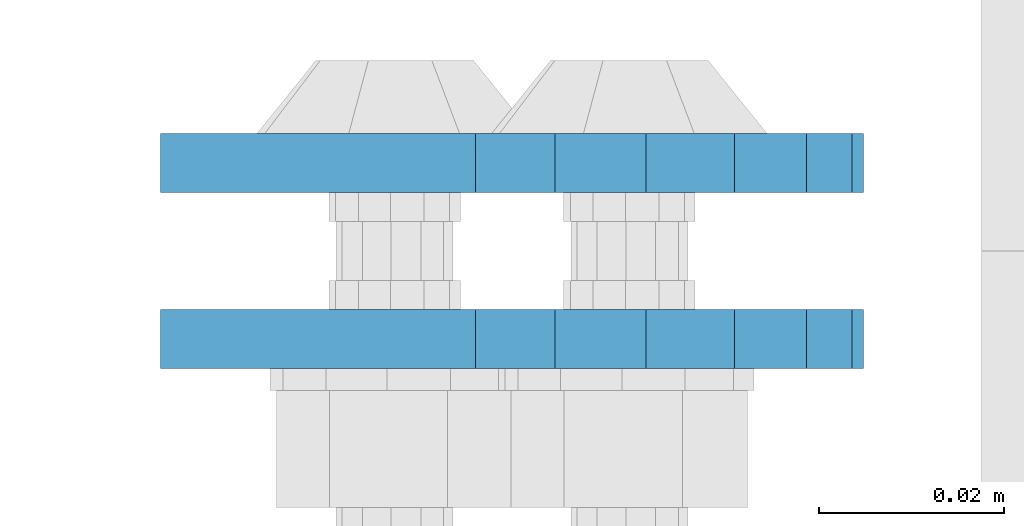
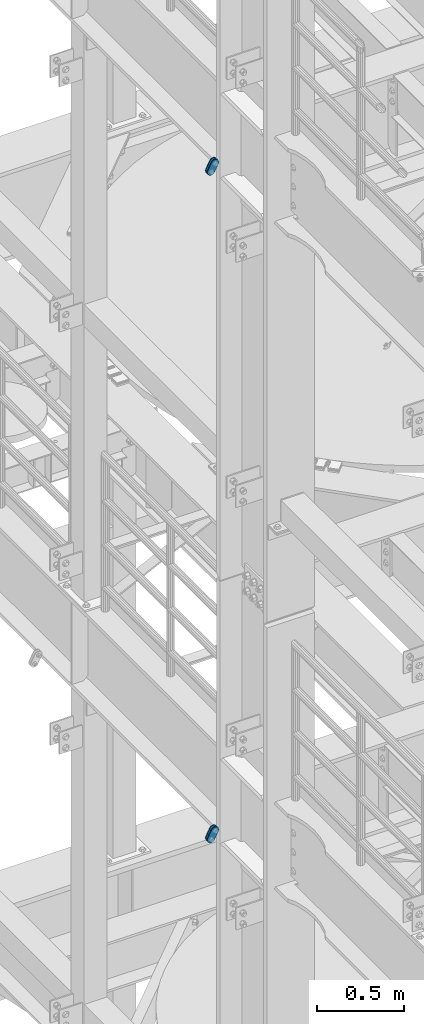
# One storey, part 1687 of 1876: 4 plates, 4 elements without a shape of their own.
"""IFC2X3 building model written with IfcOpenShell, lengths in millimetres."""

from ifc_helpers import new_model, si_unit, frame, origin_with_axes, place, context, subcontext, project, spatial, faceted_brep, material, type_object, element, aggregate, save


model = new_model("IFC2X3")

# Units and contexts
model_context = context("Model", 3, precision=1e-05, world=origin_with_axes())
body_context = subcontext(model_context, "Body", "Model", "MODEL_VIEW")
ifc_project = project(units=[si_unit("LENGTHUNIT", "METRE", prefix="MILLI"), si_unit("AREAUNIT", "SQUARE_METRE"), si_unit("VOLUMEUNIT", "CUBIC_METRE"), si_unit("MASSUNIT", "GRAM", prefix="KILO"), si_unit("TIMEUNIT", "SECOND"), si_unit("PLANEANGLEUNIT", "RADIAN"), si_unit("SOLIDANGLEUNIT", "STERADIAN"), si_unit("THERMODYNAMICTEMPERATUREUNIT", "DEGREE_CELSIUS"), si_unit("LUMINOUSINTENSITYUNIT", "LUMEN")], contexts=[model_context])

# Site, building, storey
site_placement = place(None, origin_with_axes())
site = spatial("IfcSite", under=ifc_project, at=site_placement, CompositionType="ELEMENT")
building_placement = place(site_placement, origin_with_axes())
building = spatial("IfcBuilding", under=site, at=building_placement, Name="Undefined", CompositionType="ELEMENT")
storey_placement = place(building_placement, origin_with_axes())
storey = spatial("IfcBuildingStorey", under=building, at=storey_placement, Name="Undefined", CompositionType="ELEMENT", Elevation=0.0)

# Assembly, plate
assembly_1_placement = place(storey_placement, origin_with_axes())
assembly_1 = element("IfcElementAssembly", 1, at=assembly_1_placement, inside=storey, Name="PLATE", AssemblyPlace="NOTDEFINED", PredefinedType="RIGID_FRAME")
ifc_material = material(Name="STEEL/A36")
plate_type = type_object("IfcPlateType", PredefinedType="NOTDEFINED")
plate_1_placement = place(assembly_1_placement, frame((-354.259224851121, 7610.47500303177, 17725.1776774809), z_axis=(0.894427191199916, 0.0, -0.447213595099958), x_axis=(-0.447213595099961, 6.99999707257306e-09, -0.894427191199915)))
plate_1 = element("IfcPlate", 2, at=plate_1_placement, type_object=plate_type, material=ifc_material, Name="PLATE", context=body_context, shape_type="Brep", body=[
    faceted_brep([(-8.59611645864788e-07, -3.17499999999654, 25.3999987589127), (1.93345873884391, -3.17499999999382, 35.1201580589886), (1.93345873884391, 3.17500000000564, 35.1201580589886), (-8.59611645864788e-07, 3.17500000000382, 25.3999987589132), (7.43948648259902, -3.17499999999109, 43.3605112870105), (7.43948648259902, 3.17500000000928, 43.3605112870105), (15.6798395242777, -3.17499999998654, 48.8665393096448), (15.6798395242777, 3.17500000001382, 48.8665393096448), (25.3999987589095, -3.17499999998199, 50.7999992370592), (25.3999987589095, 3.17500000001837, 50.7999992370592), (82.196130752618, -3.17499999998381, 50.7999992370605), (82.196130752618, 3.17500000001655, 50.7999992370642), (91.9162897887145, -3.17499999997926, 48.8665393918873), (91.9162897887145, 3.1750000000211, 48.8665393918909), (100.156642725027, -3.17499999997472, 43.3605115909359), (100.156642725027, 3.17500000002565, 43.3605115909395), (105.662670525982, -3.17499999997108, 35.1201586546285), (105.662670525986, 3.17500000002929, 35.1201586546358), (107.596130371159, -3.17499999996744, 25.3999996185757), (107.596130371159, 3.17500000003292, 25.3999996185794), (105.662670525981, -3.17499999996471, 15.6798405824902), (105.662670525981, 3.17500000003565, 15.6798405824939), (100.156642725024, -3.17499999996471, 7.43948764618654), (100.156642725025, 3.17500000003565, 7.43948764619017), (91.9162897887127, -3.17499999996562, 1.93345984522784), (91.9162897887127, 3.17500000003474, 1.93345984523148), (82.196130752618, -3.17499999996835, 4.54747350886464e-11), (82.196130752618, 3.1750000000311, 4.91127138957381e-11), (25.399998758905, -3.17499999999018, -8.64019966684282e-12), (25.399998758905, 3.17500000001019, -8.64019966684282e-12), (15.679839921364, -3.17499999999382, 1.9334597629304), (15.679839921364, 3.17500000000655, 1.9334597629304), (7.43948709043525, -3.17499999999654, 7.43948734220839), (7.43948709043525, 3.17500000000382, 7.43948734220885), (1.93345923228208, -3.17499999999654, 15.6798399868012), (1.93345923228208, 3.17500000000291, 15.6798399868012)], [[[0, 1, 2, 3]], [[1, 4, 5, 2]], [[4, 6, 7, 5]], [[6, 8, 9, 7]], [[8, 10, 11, 9]], [[10, 12, 13, 11]], [[12, 14, 15, 13]], [[14, 16, 17, 15]], [[16, 18, 19, 17]], [[18, 20, 21, 19]], [[20, 22, 23, 21]], [[22, 24, 25, 23]], [[24, 26, 27, 25]], [[26, 28, 29, 27]], [[28, 30, 31, 29]], [[30, 32, 33, 31]], [[32, 34, 35, 33]], [[34, 0, 3, 35]], [[5, 7, 9, 11, 13, 15, 17, 19, 21, 23, 25, 27, 29, 31, 33, 35, 3, 2]], [[34, 32, 30, 28, 26, 24, 22, 20, 18, 16, 14, 12, 10, 8, 6, 4, 1, 0]]]),
])
aggregate(assembly_1, [plate_1])

assembly_2_placement = place(storey_placement, origin_with_axes())
assembly_2 = element("IfcElementAssembly", 3, at=assembly_2_placement, inside=storey, Name="PLATE", AssemblyPlace="NOTDEFINED", PredefinedType="RIGID_FRAME")
plate_2_placement = place(assembly_2_placement, frame((-354.259224851121, 7629.53619933645, 17725.1776774809), z_axis=(0.894427191199916, 0.0, -0.447213595099958), x_axis=(-0.447213595099961, 6.99999707257306e-09, -0.894427191199915)))
plate_2 = element("IfcPlate", 4, at=plate_2_placement, type_object=plate_type, material=ifc_material, Name="PLATE", context=body_context, shape_type="Brep", body=[
    faceted_brep([(-8.59611645864788e-07, -3.17499999999654, 25.3999987589127), (1.93345873884391, -3.17499999999382, 35.1201580589886), (1.93345873884391, 3.17500000000564, 35.1201580589886), (-8.59611645864788e-07, 3.17500000000382, 25.3999987589132), (7.43948648259902, -3.17499999999109, 43.3605112870105), (7.43948648259902, 3.17500000000928, 43.3605112870105), (15.6798395242777, -3.17499999998654, 48.8665393096448), (15.6798395242777, 3.17500000001382, 48.8665393096448), (25.3999987589095, -3.17499999998199, 50.7999992370592), (25.3999987589095, 3.17500000001837, 50.7999992370592), (82.196130752618, -3.17499999998381, 50.7999992370605), (82.196130752618, 3.17500000001655, 50.7999992370642), (91.9162897887145, -3.17499999997926, 48.8665393918873), (91.9162897887145, 3.1750000000211, 48.8665393918909), (100.156642725027, -3.17499999997472, 43.3605115909359), (100.156642725027, 3.17500000002565, 43.3605115909395), (105.662670525982, -3.17499999997108, 35.1201586546285), (105.662670525986, 3.17500000002929, 35.1201586546358), (107.596130371159, -3.17499999996744, 25.3999996185757), (107.596130371159, 3.17500000003292, 25.3999996185794), (105.662670525981, -3.17499999996471, 15.6798405824902), (105.662670525981, 3.17500000003565, 15.6798405824939), (100.156642725024, -3.17499999996471, 7.43948764618654), (100.156642725025, 3.17500000003565, 7.43948764619017), (91.9162897887127, -3.17499999996562, 1.93345984522784), (91.9162897887127, 3.17500000003474, 1.93345984523148), (82.196130752618, -3.17499999996835, 4.54747350886464e-11), (82.196130752618, 3.1750000000311, 4.91127138957381e-11), (25.399998758905, -3.17499999999018, -8.64019966684282e-12), (25.399998758905, 3.17500000001019, -8.64019966684282e-12), (15.679839921364, -3.17499999999382, 1.9334597629304), (15.679839921364, 3.17500000000655, 1.9334597629304), (7.43948709043525, -3.17499999999654, 7.43948734220839), (7.43948709043525, 3.17500000000382, 7.43948734220885), (1.93345923228208, -3.17499999999654, 15.6798399868012), (1.93345923228208, 3.17500000000291, 15.6798399868012)], [[[0, 1, 2, 3]], [[1, 4, 5, 2]], [[4, 6, 7, 5]], [[6, 8, 9, 7]], [[8, 10, 11, 9]], [[10, 12, 13, 11]], [[12, 14, 15, 13]], [[14, 16, 17, 15]], [[16, 18, 19, 17]], [[18, 20, 21, 19]], [[20, 22, 23, 21]], [[22, 24, 25, 23]], [[24, 26, 27, 25]], [[26, 28, 29, 27]], [[28, 30, 31, 29]], [[30, 32, 33, 31]], [[32, 34, 35, 33]], [[34, 0, 3, 35]], [[5, 7, 9, 11, 13, 15, 17, 19, 21, 23, 25, 27, 29, 31, 33, 35, 3, 2]], [[34, 32, 30, 28, 26, 24, 22, 20, 18, 16, 14, 12, 10, 8, 6, 4, 1, 0]]]),
])
aggregate(assembly_2, [plate_2])

assembly_3_placement = place(storey_placement, origin_with_axes())
assembly_3 = element("IfcElementAssembly", 5, at=assembly_3_placement, inside=storey, Name="PLATE", AssemblyPlace="NOTDEFINED", PredefinedType="RIGID_FRAME")
plate_3_placement = place(assembly_3_placement, frame((-354.259224851122, 7610.47500303177, 13038.8776774809), z_axis=(0.894427191199916, 0.0, -0.447213595099958), x_axis=(-0.447213595099961, 6.99999707257306e-09, -0.894427191199915)))
plate_3 = element("IfcPlate", 6, at=plate_3_placement, type_object=plate_type, material=ifc_material, Name="PLATE", context=body_context, shape_type="Brep", body=[
    faceted_brep([(-8.59611645864788e-07, -3.17499999999654, 25.3999987589127), (1.93345873884391, -3.17499999999382, 35.1201580589886), (1.93345873884391, 3.17500000000564, 35.1201580589886), (-8.59611645864788e-07, 3.17500000000382, 25.3999987589132), (7.43948648259902, -3.17499999999109, 43.3605112870105), (7.43948648259902, 3.17500000000928, 43.3605112870105), (15.6798395242777, -3.17499999998654, 48.8665393096448), (15.6798395242777, 3.17500000001382, 48.8665393096448), (25.3999987589095, -3.17499999998199, 50.7999992370592), (25.3999987589095, 3.17500000001837, 50.7999992370592), (82.196130752618, -3.17499999998381, 50.7999992370605), (82.196130752618, 3.17500000001655, 50.7999992370642), (91.9162897887145, -3.17499999997926, 48.8665393918873), (91.9162897887145, 3.1750000000211, 48.8665393918909), (100.156642725027, -3.17499999997472, 43.3605115909359), (100.156642725027, 3.17500000002565, 43.3605115909395), (105.662670525982, -3.17499999997108, 35.1201586546285), (105.662670525986, 3.17500000002929, 35.1201586546358), (107.596130371159, -3.17499999996744, 25.3999996185757), (107.596130371159, 3.17500000003292, 25.3999996185794), (105.662670525981, -3.17499999996471, 15.6798405824902), (105.662670525981, 3.17500000003565, 15.6798405824939), (100.156642725024, -3.17499999996471, 7.43948764618654), (100.156642725025, 3.17500000003565, 7.43948764619017), (91.9162897887127, -3.17499999996562, 1.93345984522784), (91.9162897887127, 3.17500000003474, 1.93345984523148), (82.196130752618, -3.17499999996835, 4.54747350886464e-11), (82.196130752618, 3.1750000000311, 4.91127138957381e-11), (25.399998758905, -3.17499999999018, -8.64019966684282e-12), (25.399998758905, 3.17500000001019, -8.64019966684282e-12), (15.679839921364, -3.17499999999382, 1.9334597629304), (15.679839921364, 3.17500000000655, 1.9334597629304), (7.43948709043525, -3.17499999999654, 7.43948734220839), (7.43948709043525, 3.17500000000382, 7.43948734220885), (1.93345923228208, -3.17499999999654, 15.6798399868012), (1.93345923228208, 3.17500000000291, 15.6798399868012)], [[[0, 1, 2, 3]], [[1, 4, 5, 2]], [[4, 6, 7, 5]], [[6, 8, 9, 7]], [[8, 10, 11, 9]], [[10, 12, 13, 11]], [[12, 14, 15, 13]], [[14, 16, 17, 15]], [[16, 18, 19, 17]], [[18, 20, 21, 19]], [[20, 22, 23, 21]], [[22, 24, 25, 23]], [[24, 26, 27, 25]], [[26, 28, 29, 27]], [[28, 30, 31, 29]], [[30, 32, 33, 31]], [[32, 34, 35, 33]], [[34, 0, 3, 35]], [[5, 7, 9, 11, 13, 15, 17, 19, 21, 23, 25, 27, 29, 31, 33, 35, 3, 2]], [[34, 32, 30, 28, 26, 24, 22, 20, 18, 16, 14, 12, 10, 8, 6, 4, 1, 0]]]),
])
aggregate(assembly_3, [plate_3])

assembly_4_placement = place(storey_placement, origin_with_axes())
assembly_4 = element("IfcElementAssembly", 7, at=assembly_4_placement, inside=storey, Name="PLATE", AssemblyPlace="NOTDEFINED", PredefinedType="RIGID_FRAME")
plate_4_placement = place(assembly_4_placement, frame((-354.259224851122, 7629.53619933645, 13038.8776774809), z_axis=(0.894427191199916, 0.0, -0.447213595099958), x_axis=(-0.447213595099961, 6.99999707257306e-09, -0.894427191199915)))
plate_4 = element("IfcPlate", 8, at=plate_4_placement, type_object=plate_type, material=ifc_material, Name="PLATE", context=body_context, shape_type="Brep", body=[
    faceted_brep([(-8.59611645864788e-07, -3.17499999999654, 25.3999987589127), (1.93345873884391, -3.17499999999382, 35.1201580589886), (1.93345873884391, 3.17500000000564, 35.1201580589886), (-8.59611645864788e-07, 3.17500000000382, 25.3999987589132), (7.43948648259902, -3.17499999999109, 43.3605112870105), (7.43948648259902, 3.17500000000928, 43.3605112870105), (15.6798395242777, -3.17499999998654, 48.8665393096448), (15.6798395242777, 3.17500000001382, 48.8665393096448), (25.3999987589095, -3.17499999998199, 50.7999992370592), (25.3999987589095, 3.17500000001837, 50.7999992370592), (82.196130752618, -3.17499999998381, 50.7999992370605), (82.196130752618, 3.17500000001655, 50.7999992370642), (91.9162897887145, -3.17499999997926, 48.8665393918873), (91.9162897887145, 3.1750000000211, 48.8665393918909), (100.156642725027, -3.17499999997472, 43.3605115909359), (100.156642725027, 3.17500000002565, 43.3605115909395), (105.662670525982, -3.17499999997108, 35.1201586546285), (105.662670525986, 3.17500000002929, 35.1201586546358), (107.596130371159, -3.17499999996744, 25.3999996185757), (107.596130371159, 3.17500000003292, 25.3999996185794), (105.662670525981, -3.17499999996471, 15.6798405824902), (105.662670525981, 3.17500000003565, 15.6798405824939), (100.156642725024, -3.17499999996471, 7.43948764618654), (100.156642725025, 3.17500000003565, 7.43948764619017), (91.9162897887127, -3.17499999996562, 1.93345984522784), (91.9162897887127, 3.17500000003474, 1.93345984523148), (82.196130752618, -3.17499999996835, 4.54747350886464e-11), (82.196130752618, 3.1750000000311, 4.91127138957381e-11), (25.399998758905, -3.17499999999018, -8.64019966684282e-12), (25.399998758905, 3.17500000001019, -8.64019966684282e-12), (15.679839921364, -3.17499999999382, 1.9334597629304), (15.679839921364, 3.17500000000655, 1.9334597629304), (7.43948709043525, -3.17499999999654, 7.43948734220839), (7.43948709043525, 3.17500000000382, 7.43948734220885), (1.93345923228208, -3.17499999999654, 15.6798399868012), (1.93345923228208, 3.17500000000291, 15.6798399868012)], [[[0, 1, 2, 3]], [[1, 4, 5, 2]], [[4, 6, 7, 5]], [[6, 8, 9, 7]], [[8, 10, 11, 9]], [[10, 12, 13, 11]], [[12, 14, 15, 13]], [[14, 16, 17, 15]], [[16, 18, 19, 17]], [[18, 20, 21, 19]], [[20, 22, 23, 21]], [[22, 24, 25, 23]], [[24, 26, 27, 25]], [[26, 28, 29, 27]], [[28, 30, 31, 29]], [[30, 32, 33, 31]], [[32, 34, 35, 33]], [[34, 0, 3, 35]], [[5, 7, 9, 11, 13, 15, 17, 19, 21, 23, 25, 27, 29, 31, 33, 35, 3, 2]], [[34, 32, 30, 28, 26, 24, 22, 20, 18, 16, 14, 12, 10, 8, 6, 4, 1, 0]]]),
])
aggregate(assembly_4, [plate_4])

save(model, "model.ifc")
